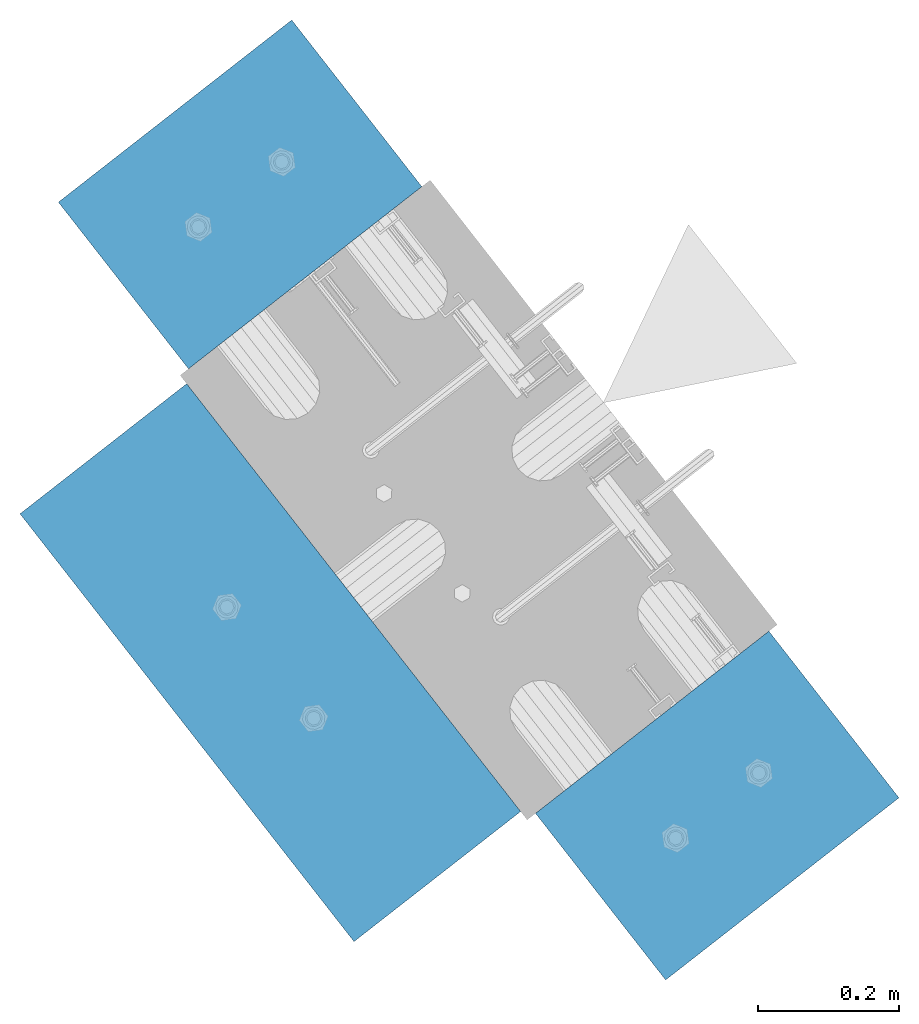
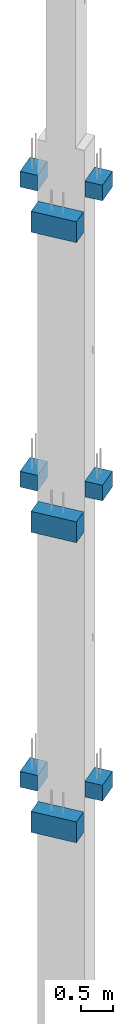
# One storey, part 18 of 42: 9 slabs, 1 element without a shape of its own.
"""IFC2X3 building model written with IfcOpenShell, lengths in millimetres."""

from ifc_helpers import new_model, si_unit, frame, origin_with_axes, place, context, subcontext, project, spatial, faceted_brep, material, type_object, element, aggregate, save


model = new_model("IFC2X3")

# Units and contexts
model_context = context("Model", 3, precision=1e-05, world=origin_with_axes())
body_context = subcontext(model_context, "Body", "Model", "MODEL_VIEW")
ifc_project = project(units=[si_unit("LENGTHUNIT", "METRE", prefix="MILLI"), si_unit("AREAUNIT", "SQUARE_METRE"), si_unit("VOLUMEUNIT", "CUBIC_METRE"), si_unit("MASSUNIT", "GRAM", prefix="KILO"), si_unit("TIMEUNIT", "SECOND"), si_unit("PLANEANGLEUNIT", "RADIAN"), si_unit("SOLIDANGLEUNIT", "STERADIAN"), si_unit("THERMODYNAMICTEMPERATUREUNIT", "DEGREE_CELSIUS"), si_unit("LUMINOUSINTENSITYUNIT", "LUMEN")], contexts=[model_context])

# Site, building, storey
site_placement = place(None, frame((171687.4, 84828.52, 14700.0), z_axis=(0.0, 0.0, 1.0), x_axis=(1.0, 0.0, 0.0)))
site = spatial("IfcSite", under=ifc_project, at=site_placement, CompositionType="ELEMENT")
building_placement = place(site_placement, origin_with_axes())
building = spatial("IfcBuilding", under=site, at=building_placement, Name="Undefined", CompositionType="ELEMENT")
storey_placement = place(building_placement, origin_with_axes())
storey = spatial("IfcBuildingStorey", under=building, at=storey_placement, Name="Undefined", CompositionType="ELEMENT", Elevation=0.0)

# Assembly, slabs
assembly_placement = place(storey_placement, origin_with_axes())
assembly = element("IfcElementAssembly", 1, at=assembly_placement, inside=storey, AssemblyPlace="NOTDEFINED", PredefinedType="REINFORCEMENT_UNIT")
ifc_material = material(Name="CONCRETE/C50/60")
slab_type_1 = type_object("IfcSlabType", PredefinedType="NOTDEFINED")
slab_1_placement = place(assembly_placement, frame((17666.015211748, 265901.046335652, 5650.0), z_axis=(0.0, 0.0, -1.0), x_axis=(0.615386370178831, -0.788225611990706, 0.0)))
slab_1 = element("IfcSlab", 2, at=slab_1_placement, type_object=slab_type_1, material=ifc_material, Name="CONSOLE", PredefinedType="FLOOR", context=body_context, shape_type="Brep", body=[
    faceted_brep([(2.97441147267818e-07, -209.999999783293, 0.0), (2.97441147267818e-07, -209.999999783293, 300.0), (2.99507519230247e-07, 210.000000216387, 300.0), (2.99507519230247e-07, 210.000000216387, 0.0), (300.000000297325, -209.99999978402, 300.0), (300.000000299391, 210.000000215659, 300.0), (300.000000297325, -209.99999978402, 0.0), (300.000000299391, 210.000000215659, 0.0)], [[[0, 1, 2, 3]], [[1, 4, 5, 2]], [[4, 6, 7, 5]], [[6, 0, 3, 7]], [[5, 7, 3, 2]], [[6, 4, 1, 0]]]),
])
slab_2_placement = place(assembly_placement, frame((17666.0152117478, 265901.046335651, 17170.0), z_axis=(0.0, 0.0, -1.0), x_axis=(0.615386370178831, -0.788225611990706, 0.0)))
slab_2 = element("IfcSlab", 3, at=slab_2_placement, type_object=slab_type_1, material=ifc_material, Name="CONSOLE", PredefinedType="FLOOR", context=body_context, shape_type="Brep", body=[
    faceted_brep([(2.97441147267818e-07, -209.999999783293, 0.0), (2.97441147267818e-07, -209.999999783293, 300.0), (2.99507519230247e-07, 210.000000216387, 300.0), (2.99507519230247e-07, 210.000000216387, 0.0), (300.000000297325, -209.99999978402, 300.0), (300.000000299391, 210.000000215659, 300.0), (300.000000297325, -209.99999978402, 0.0), (300.000000299391, 210.000000215659, 0.0)], [[[0, 1, 2, 3]], [[1, 4, 5, 2]], [[4, 6, 7, 5]], [[6, 0, 3, 7]], [[5, 7, 3, 2]], [[6, 4, 1, 0]]]),
])
slab_3_placement = place(assembly_placement, frame((18527.5561299914, 264797.530478861, 11510.0), z_axis=(0.0, 0.0, -1.0), x_axis=(-0.615386219627735, 0.788225729529483, 0.0)))
slab_3 = element("IfcSlab", 4, at=slab_3_placement, type_object=slab_type_1, material=ifc_material, Name="CONSOLE", PredefinedType="FLOOR", context=body_context, shape_type="Brep", body=[
    faceted_brep([(2.97441147267818e-07, -209.999999783293, 0.0), (2.97441147267818e-07, -209.999999783293, 300.0), (2.99507519230247e-07, 210.000000216387, 300.0), (2.99507519230247e-07, 210.000000216387, 0.0), (300.000000297325, -209.99999978402, 300.0), (300.000000299391, 210.000000215659, 300.0), (300.000000297325, -209.99999978402, 0.0), (300.000000299391, 210.000000215659, 0.0)], [[[0, 1, 2, 3]], [[1, 4, 5, 2]], [[4, 6, 7, 5]], [[6, 0, 3, 7]], [[5, 7, 3, 2]], [[6, 4, 1, 0]]]),
])
slab_4_placement = place(assembly_placement, frame((18527.5561299914, 264797.530478861, 17270.0), z_axis=(0.0, 0.0, -1.0), x_axis=(-0.615386219627735, 0.788225729529483, 0.0)))
slab_4 = element("IfcSlab", 5, at=slab_4_placement, type_object=slab_type_1, material=ifc_material, Name="CONSOLE", PredefinedType="FLOOR", context=body_context, shape_type="Brep", body=[
    faceted_brep([(2.97441147267818e-07, -209.999999783293, 0.0), (2.97441147267818e-07, -209.999999783293, 300.0), (2.99507519230247e-07, 210.000000216387, 300.0), (2.99507519230247e-07, 210.000000216387, 0.0), (300.000000297325, -209.99999978402, 300.0), (300.000000299391, 210.000000215659, 300.0), (300.000000297325, -209.99999978402, 0.0), (300.000000299391, 210.000000215659, 0.0)], [[[0, 1, 2, 3]], [[1, 4, 5, 2]], [[4, 6, 7, 5]], [[6, 0, 3, 7]], [[5, 7, 3, 2]], [[6, 4, 1, 0]]]),
])
slab_5_placement = place(assembly_placement, frame((17666.015211748, 265901.046335652, 11410.0), z_axis=(0.0, 0.0, -1.0), x_axis=(0.615386370178831, -0.788225611990706, 0.0)))
slab_5 = element("IfcSlab", 6, at=slab_5_placement, type_object=slab_type_1, material=ifc_material, Name="CONSOLE", PredefinedType="FLOOR", context=body_context, shape_type="Brep", body=[
    faceted_brep([(2.97441147267818e-07, -209.999999783293, 0.0), (2.97441147267818e-07, -209.999999783293, 300.0), (2.99507519230247e-07, 210.000000216387, 300.0), (2.99507519230247e-07, 210.000000216387, 0.0), (300.000000297325, -209.99999978402, 300.0), (300.000000299391, 210.000000215659, 300.0), (300.000000297325, -209.99999978402, 0.0), (300.000000299391, 210.000000215659, 0.0)], [[[0, 1, 2, 3]], [[1, 4, 5, 2]], [[4, 6, 7, 5]], [[6, 0, 3, 7]], [[5, 7, 3, 2]], [[6, 4, 1, 0]]]),
])
slab_6_placement = place(assembly_placement, frame((18527.5561299915, 264797.530478861, 5749.99999999999), z_axis=(0.0, 0.0, -1.0), x_axis=(-0.615386219627735, 0.788225729529483, 0.0)))
slab_6 = element("IfcSlab", 7, at=slab_6_placement, type_object=slab_type_1, material=ifc_material, Name="CONSOLE", PredefinedType="FLOOR", context=body_context, shape_type="Brep", body=[
    faceted_brep([(2.97441147267818e-07, -209.999999783293, 0.0), (2.97441147267818e-07, -209.999999783293, 300.0), (2.99507519230247e-07, 210.000000216387, 300.0), (2.99507519230247e-07, 210.000000216387, 0.0), (300.000000297325, -209.99999978402, 300.0), (300.000000299391, 210.000000215659, 300.0), (300.000000297325, -209.99999978402, 0.0), (300.000000299391, 210.000000215659, 0.0)], [[[0, 1, 2, 3]], [[1, 4, 5, 2]], [[4, 6, 7, 5]], [[6, 0, 3, 7]], [[5, 7, 3, 2]], [[6, 4, 1, 0]]]),
])
slab_type_2 = type_object("IfcSlabType", PredefinedType="NOTDEFINED")
slab_7_placement = place(assembly_placement, frame((17682.9672245762, 265026.210562913, 10930.0), z_axis=(0.0, 0.0, -1.0), x_axis=(0.788225729527905, 0.615386219629756, 9.99999974740041e-10)))
slab_7 = element("IfcSlab", 8, at=slab_7_placement, type_object=slab_type_2, material=ifc_material, Name="CONSOLE", PredefinedType="FLOOR", context=body_context, shape_type="Brep", body=[
    faceted_brep([(-2.13651219382882e-07, -384.999999702006, 0.0), (-2.13651219382882e-07, -384.999999702006, 400.0), (-2.17580236494541e-07, 385.000000297674, 400.0), (-2.17580236494541e-07, 385.000000297674, 0.0), (299.999999786145, -384.999999701249, 400.0), (299.999999782216, 385.000000298431, 400.0), (299.999999786145, -384.999999701249, 0.0), (299.999999782216, 385.000000298431, 0.0)], [[[0, 1, 2, 3]], [[1, 4, 5, 2]], [[4, 6, 7, 5]], [[6, 0, 3, 7]], [[5, 7, 3, 2]], [[6, 4, 1, 0]]]),
])
slab_8_placement = place(assembly_placement, frame((17682.9672245762, 265026.210562913, 16690.0), z_axis=(0.0, 0.0, -1.0), x_axis=(0.788225729527905, 0.615386219629756, 9.99999974740041e-10)))
slab_8 = element("IfcSlab", 9, at=slab_8_placement, type_object=slab_type_2, material=ifc_material, Name="CONSOLE", PredefinedType="FLOOR", context=body_context, shape_type="Brep", body=[
    faceted_brep([(-2.13651219382882e-07, -384.999999702006, 0.0), (-2.13651219382882e-07, -384.999999702006, 400.0), (-2.17580236494541e-07, 385.000000297674, 400.0), (-2.17580236494541e-07, 385.000000297674, 0.0), (299.999999786145, -384.999999701249, 400.0), (299.999999782216, 385.000000298431, 400.0), (299.999999786145, -384.999999701249, 0.0), (299.999999782216, 385.000000298431, 0.0)], [[[0, 1, 2, 3]], [[1, 4, 5, 2]], [[4, 6, 7, 5]], [[6, 0, 3, 7]], [[5, 7, 3, 2]], [[6, 4, 1, 0]]]),
])
slab_9_placement = place(assembly_placement, frame((17682.9672245762, 265026.210562913, 5169.99999999999), z_axis=(0.0, 0.0, -1.0), x_axis=(0.788225729527905, 0.615386219629756, 9.99999974740041e-10)))
slab_9 = element("IfcSlab", 10, at=slab_9_placement, type_object=slab_type_2, material=ifc_material, Name="CONSOLE", PredefinedType="FLOOR", context=body_context, shape_type="Brep", body=[
    faceted_brep([(-2.13651219382882e-07, -384.999999702006, 0.0), (-2.13651219382882e-07, -384.999999702006, 400.0), (-2.17580236494541e-07, 385.000000297674, 400.0), (-2.17580236494541e-07, 385.000000297674, 0.0), (299.999999786145, -384.999999701249, 400.0), (299.999999782216, 385.000000298431, 400.0), (299.999999786145, -384.999999701249, 0.0), (299.999999782216, 385.000000298431, 0.0)], [[[0, 1, 2, 3]], [[1, 4, 5, 2]], [[4, 6, 7, 5]], [[6, 0, 3, 7]], [[5, 7, 3, 2]], [[6, 4, 1, 0]]]),
])
aggregate(assembly, [slab_1, slab_2, slab_7, slab_3, slab_4, slab_8, slab_9, slab_5, slab_6])

save(model, "model.ifc")
